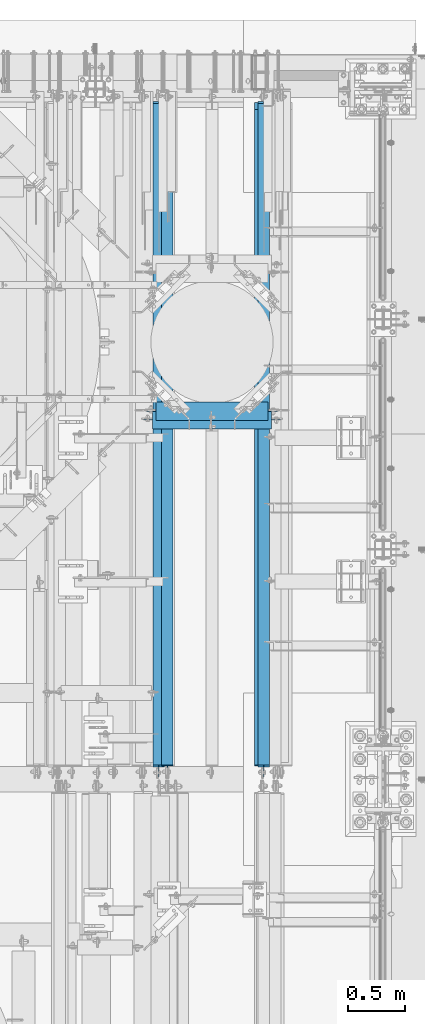
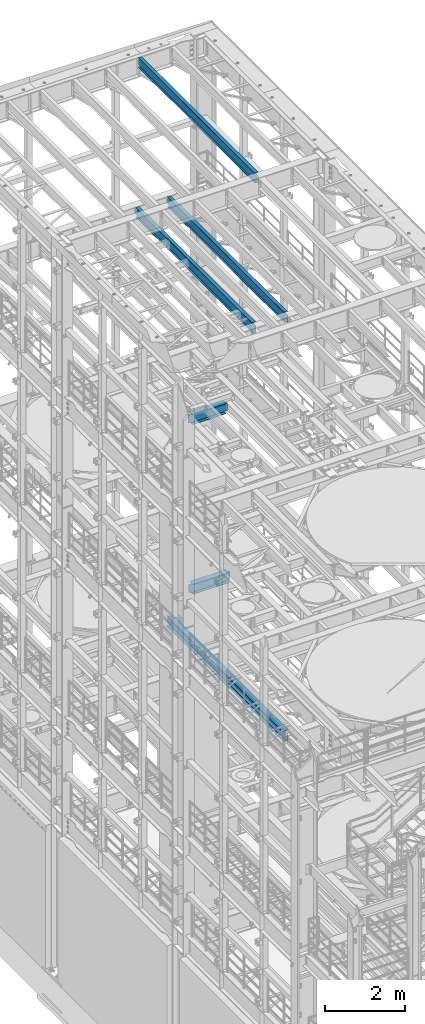
# One storey, part 1062 of 1876: 6 beams, 6 elements without a shape of their own.
"""IFC2X3 building model written with IfcOpenShell, lengths in millimetres."""

from ifc_helpers import new_model, si_unit, frame, origin_with_axes, place, context, subcontext, project, spatial, faceted_brep, material, type_object, element, aggregate, save


model = new_model("IFC2X3")

# Units and contexts
model_context = context("Model", 3, precision=1e-05, world=origin_with_axes())
body_context = subcontext(model_context, "Body", "Model", "MODEL_VIEW")
ifc_project = project(units=[si_unit("LENGTHUNIT", "METRE", prefix="MILLI"), si_unit("AREAUNIT", "SQUARE_METRE"), si_unit("VOLUMEUNIT", "CUBIC_METRE"), si_unit("MASSUNIT", "GRAM", prefix="KILO"), si_unit("TIMEUNIT", "SECOND"), si_unit("PLANEANGLEUNIT", "RADIAN"), si_unit("SOLIDANGLEUNIT", "STERADIAN"), si_unit("THERMODYNAMICTEMPERATUREUNIT", "DEGREE_CELSIUS"), si_unit("LUMINOUSINTENSITYUNIT", "LUMEN")], contexts=[model_context])

# Site, building, storey
site_placement = place(None, origin_with_axes())
site = spatial("IfcSite", under=ifc_project, at=site_placement, CompositionType="ELEMENT")
building_placement = place(site_placement, origin_with_axes())
building = spatial("IfcBuilding", under=site, at=building_placement, Name="Undefined", CompositionType="ELEMENT")
storey_placement = place(building_placement, origin_with_axes())
storey = spatial("IfcBuildingStorey", under=building, at=storey_placement, Name="Undefined", CompositionType="ELEMENT", Elevation=0.0)

# Assembly, beam
assembly_1_placement = place(storey_placement, origin_with_axes())
assembly_1 = element("IfcElementAssembly", 1, at=assembly_1_placement, inside=storey, Name="BEAM", AssemblyPlace="NOTDEFINED", PredefinedType="RIGID_FRAME")
ifc_material_1 = material(Name="STEEL/A992")
beam_type_1 = type_object("IfcBeamType", Name="W12X26", PredefinedType="NOTDEFINED")
beam_1_placement = place(assembly_1_placement, frame((5524.5, 10871.1471065215, 13154.025), z_axis=(0.0, 0.0, 1.0), x_axis=(1.0, 0.0, 0.0)))
beam_1 = element("IfcBeam", 2, at=beam_1_placement, type_object=beam_type_1, material=ifc_material_1, Name="BEAM", ObjectType="W12X26", context=body_context, shape_type="Brep", body=[
    faceted_brep([(6.34999999999945, -3.17499999999927, -130.175000000001), (6.34999999999945, 3.17499999999927, -130.175000000001), (82.550000190734, 3.17499999999927, -130.175000000001), (82.550000190734, -3.17499999999927, -130.175000000001), (87.4100797087794, 3.17499999999927, -131.141729922589), (87.4100797087794, -3.17499999999927, -131.141729922589), (91.5302561769331, 3.17499999999927, -133.894743823066), (91.5302561769331, -3.17499999999927, -133.894743823066), (94.2832700774115, 3.17499999999927, -138.01492029122), (94.2832700774115, -3.17499999999927, -138.01492029122), (95.2499999999991, -3.17499999999927, -142.874999809266), (95.2499999999991, 3.17499999999927, -142.874999809266), (95.2499999999991, 3.17499999999927, -146.049999999999), (95.2499999999991, 82.5499999999993, -146.049999999999), (95.2499999999991, 82.5499999999993, -155.575000000001), (95.2499999999991, -82.5499999999993, -155.575000000001), (95.2499999999991, -82.5499999999993, -146.049999999999), (95.2499999999991, -3.17499999999927, -146.049999999999), (1079.5, 82.5499999999993, 146.049999999999), (1079.5, 3.17499999999927, 146.049999999999), (88.8999999999996, 3.17499999999927, 146.049999999999), (88.8999999999996, 82.5499999999993, 146.049999999999), (76.2000001907345, -3.17499999999927, 130.175000000001), (76.2000001907345, 3.17499999999927, 130.175000000001), (6.34999999999945, 3.17499999999927, 130.175000000001), (6.34999999999945, -3.17499999999927, 130.175000000001), (81.06007970878, -3.17499999999927, 131.141729922589), (81.06007970878, 3.17499999999927, 131.141729922589), (85.1802561769337, -3.17499999999927, 133.894743823066), (85.1802561769337, 3.17499999999927, 133.894743823066), (87.9332700774121, -3.17499999999927, 138.01492029122), (87.9332700774121, 3.17499999999927, 138.01492029122), (88.8999999999996, -3.17499999999927, 142.874999809266), (88.8999999999996, 3.17499999999927, 142.874999809266), (1079.5, -82.5499999999993, 155.575000000001), (1079.5, 82.5499999999993, 155.575000000001), (88.8999999999996, 82.5499999999993, 155.575000000001), (88.8999999999996, -82.5499999999993, 155.575000000001), (1079.5, -82.5499999999993, 146.049999999999), (88.8999999999996, -82.5499999999993, 146.049999999999), (1079.5, -3.17499999999927, 146.049999999999), (88.8999999999996, -3.17499999999927, 146.049999999999), (1079.5, -3.17499999999927, 142.874999809266), (1079.5, 3.17499999999927, 142.874999809266), (1080.46672992259, -3.17499999999927, 138.01492029122), (1080.46672992259, 3.17499999999927, 138.01492029122), (1083.21974382307, -3.17499999999927, 133.894743823066), (1083.21974382307, 3.17499999999927, 133.894743823066), (1087.33992029122, -3.17499999999927, 131.141729922589), (1087.33992029122, 3.17499999999927, 131.141729922589), (1092.19999980927, -3.17499999999927, 130.175000000001), (1092.19999980927, 3.17499999999927, 130.175000000001), (1162.05, -3.17499999999927, 130.175000000001), (1162.05, 3.17499999999927, 130.175000000001), (1162.05, -3.17499999999927, -130.175000000001), (1162.05, 3.17499999999927, -130.175000000001), (1085.84999980927, -3.17499999999927, -130.175000000001), (1085.84999980927, 3.17499999999927, -130.175000000001), (1080.98992029122, -3.17499999999927, -131.141729922589), (1080.98992029122, 3.17499999999927, -131.141729922589), (1076.86974382307, -3.17499999999927, -133.894743823066), (1076.86974382307, 3.17499999999927, -133.894743823066), (1074.11672992259, -3.17499999999927, -138.01492029122), (1074.11672992259, 3.17499999999927, -138.01492029122), (1073.15, -3.17499999999927, -142.874999809266), (1073.15, 3.17499999999927, -142.874999809266), (1073.15, -3.17499999999927, -146.049999999999), (1073.15, -82.5499999999993, -146.049999999999), (1073.15, -82.5499999999993, -155.575000000001), (1073.15, 82.5499999999993, -155.575000000001), (1073.15, 82.5499999999993, -146.049999999999), (1073.15, 3.17499999999927, -146.049999999999)], [[[0, 1, 2, 3]], [[3, 2, 4, 5]], [[5, 4, 6, 7]], [[7, 6, 8, 9]], [[10, 11, 12, 13, 14, 15, 16, 17]], [[9, 8, 11, 10]], [[18, 19, 20, 21]], [[22, 23, 24, 25]], [[26, 27, 23, 22]], [[28, 29, 27, 26]], [[30, 31, 29, 28]], [[32, 33, 31, 30]], [[34, 35, 36, 37]], [[38, 34, 37, 39]], [[40, 38, 39, 41]], [[37, 36, 21, 20, 33, 32, 41, 39]], [[35, 18, 21, 36]], [[34, 38, 40, 42, 43, 19, 18, 35]], [[44, 45, 43, 42]], [[46, 47, 45, 44]], [[48, 49, 47, 46]], [[50, 51, 49, 48]], [[52, 53, 51, 50]], [[53, 52, 54, 55]], [[54, 56, 57, 55]], [[58, 59, 57, 56]], [[60, 61, 59, 58]], [[62, 63, 61, 60]], [[64, 65, 63, 62]], [[66, 67, 68, 69, 70, 71, 65, 64]], [[67, 66, 17, 16]], [[68, 67, 16, 15]], [[69, 68, 15, 14]], [[70, 69, 14, 13]], [[71, 70, 13, 12]], [[6, 4, 2, 1, 24, 23, 27, 29, 31, 33, 20, 19, 43, 45, 47, 49, 51, 53, 55, 57, 59, 61, 63, 65, 71, 12, 11, 8]], [[25, 24, 1, 0]], [[66, 64, 62, 60, 58, 56, 54, 52, 50, 48, 46, 44, 42, 40, 41, 32, 30, 28, 26, 22, 25, 0, 3, 5, 7, 9, 10, 17]]]),
])
aggregate(assembly_1, [beam_1])

assembly_2_placement = place(storey_placement, origin_with_axes())
assembly_2 = element("IfcElementAssembly", 3, at=assembly_2_placement, inside=storey, Name="BEAM", AssemblyPlace="NOTDEFINED", PredefinedType="RIGID_FRAME")
ifc_material_2 = material(Name="STEEL/A36")
beam_2_placement = place(assembly_2_placement, frame((5486.4, 10795.0, 7997.825), z_axis=(0.0, 0.0, -1.0), x_axis=(1.0, 0.0, 0.0)))
beam_2 = element("IfcBeam", 4, at=beam_2_placement, type_object=beam_type_1, material=ifc_material_2, Name="BEAM", ObjectType="W12X26", context=body_context, shape_type="Brep", body=[
    faceted_brep([(1146.175, -3.17499999999927, -146.05), (1146.175, -82.5499999999993, -146.05), (1146.175, -82.5499999999993, -155.575), (1146.175, 82.5499999999993, -155.575), (1146.175, 82.5499999999993, -146.05), (1146.175, 3.17499999999927, -146.05), (1146.175, 3.17499999999927, -142.874999809266), (1146.175, -3.17499999999927, -142.874999809266), (1147.14172992259, 3.17499999999927, -138.014920291221), (1147.14172992259, -3.17499999999927, -138.014920291221), (1149.89474382307, 3.17499999999927, -133.894743823067), (1149.89474382307, -3.17499999999927, -133.894743823067), (1154.01492029122, 3.17499999999927, -131.141729922589), (1154.01492029122, -3.17499999999927, -131.141729922589), (1158.87499980927, 3.17499999999927, -130.175000000001), (1158.87499980927, -3.17499999999927, -130.175000000001), (1228.725, -3.17499999999927, -130.175000000001), (1228.725, 3.17499999999927, -130.175000000001), (1139.825, 82.5499999999993, 146.05), (1139.825, 3.17499999999927, 146.05), (104.774999999999, 3.17499999999927, 146.05), (104.774999999999, 82.5499999999993, 146.05), (98.4250000000002, -3.17500000000018, -142.874999809268), (98.4250000000002, 3.17500000000018, -142.874999809268), (98.4250000000029, 3.17500000000018, -146.049999999999), (98.4250000000002, 82.5500000000002, -146.049999999999), (98.4250000000002, 82.5500000000002, -155.575000000001), (98.4250000000002, -82.5500000000002, -155.575000000001), (98.4250000000002, -82.5500000000002, -146.049999999999), (98.4250000000029, -3.17500000000018, -146.049999999999), (97.4582700774126, -3.17500000000018, -138.014920291222), (97.4582700774126, 3.17500000000018, -138.014920291222), (94.7052561769342, -3.17500000000018, -133.894743823068), (94.7052561769342, 3.17500000000018, -133.894743823068), (90.5850797087805, -3.17500000000018, -131.14172992259), (90.5850797087805, 3.17500000000018, -131.14172992259), (85.725000190735, -3.17500000000018, -130.175000000003), (85.725000190735, 3.17500000000018, -130.175000000003), (15.875, -3.17500000000018, -130.175000000003), (15.875, 3.17500000000018, -130.175000000003), (15.8749999999991, -3.17499999999927, 123.824999999999), (15.8749999999991, 3.17499999999927, 123.824999999999), (92.0750001907336, -3.17499999999927, 123.824999999999), (92.0750001907336, 3.17499999999927, 123.824999999999), (96.9350797087791, -3.17499999999927, 124.791729922586), (96.9350797087791, 3.17499999999927, 124.791729922586), (101.055256176933, -3.17499999999927, 127.544743823065), (101.055256176933, 3.17499999999927, 127.544743823065), (103.808270077411, -3.17499999999927, 131.664920291219), (103.808270077411, 3.17499999999927, 131.664920291219), (104.774999999999, -3.17499999999927, 136.524999809264), (104.774999999999, 3.17499999999927, 136.524999809264), (1139.825, -82.5499999999993, 155.575), (1139.825, 82.5499999999993, 155.575), (104.774999999999, 82.5499999999993, 155.575), (104.774999999999, -82.5499999999993, 155.575), (1139.825, -82.5499999999993, 146.05), (104.774999999999, -82.5499999999993, 146.05), (1139.825, -3.17499999999927, 146.05), (104.774999999999, -3.17499999999927, 146.05), (1139.825, -3.17499999999927, 136.524999809264), (1139.825, 3.17499999999927, 136.524999809264), (1140.79172992259, -3.17499999999927, 131.664920291219), (1140.79172992259, 3.17499999999927, 131.664920291219), (1143.54474382307, -3.17499999999927, 127.544743823065), (1143.54474382307, 3.17499999999927, 127.544743823065), (1147.66492029122, -3.17499999999927, 124.791729922586), (1147.66492029122, 3.17499999999927, 124.791729922586), (1152.52499980927, -3.17499999999927, 123.824999999999), (1152.52499980927, 3.17499999999927, 123.824999999999), (1228.725, -3.17499999999927, 123.824999999999), (1228.725, 3.17499999999927, 123.824999999999)], [[[0, 1, 2, 3, 4, 5, 6, 7]], [[7, 6, 8, 9]], [[9, 8, 10, 11]], [[11, 10, 12, 13]], [[13, 12, 14, 15]], [[16, 15, 14, 17]], [[18, 19, 20, 21]], [[22, 23, 24, 25, 26, 27, 28, 29]], [[30, 31, 23, 22]], [[32, 33, 31, 30]], [[34, 35, 33, 32]], [[36, 37, 35, 34]], [[38, 39, 37, 36]], [[40, 41, 39, 38]], [[42, 43, 41, 40]], [[44, 45, 43, 42]], [[46, 47, 45, 44]], [[48, 49, 47, 46]], [[50, 51, 49, 48]], [[52, 53, 54, 55]], [[56, 52, 55, 57]], [[58, 56, 57, 59]], [[55, 54, 21, 20, 51, 50, 59, 57]], [[53, 18, 21, 54]], [[52, 56, 58, 60, 61, 19, 18, 53]], [[62, 63, 61, 60]], [[64, 65, 63, 62]], [[66, 67, 65, 64]], [[68, 69, 67, 66]], [[70, 71, 69, 68]], [[71, 70, 16, 17]], [[12, 10, 8, 6, 5, 24, 23, 31, 33, 35, 37, 39, 41, 43, 45, 47, 49, 51, 20, 19, 61, 63, 65, 67, 69, 71, 17, 14]], [[25, 24, 5, 4]], [[26, 25, 4, 3]], [[27, 26, 3, 2]], [[28, 27, 2, 1]], [[29, 28, 1, 0]], [[70, 68, 66, 64, 62, 60, 58, 59, 50, 48, 46, 44, 42, 40, 38, 36, 34, 32, 30, 22, 29, 0, 7, 9, 11, 13, 15, 16]]]),
])
aggregate(assembly_2, [beam_2])

assembly_3_placement = place(storey_placement, origin_with_axes())
assembly_3 = element("IfcElementAssembly", 5, at=assembly_3_placement, inside=storey, Name="BEAM", AssemblyPlace="NOTDEFINED", PredefinedType="RIGID_FRAME")
beam_type_2 = type_object("IfcBeamType", Name="W12X16", PredefinedType="NOTDEFINED")
beam_3_placement = place(assembly_3_placement, frame((6565.9, 7620.0, 17830.8), z_axis=(0.0, 0.0, 1.0), x_axis=(0.0, 1.0, 0.0)))
beam_3 = element("IfcBeam", 6, at=beam_3_placement, type_object=beam_type_2, material=ifc_material_1, Name="BEAM", ObjectType="W12X16", context=body_context, shape_type="Brep", body=[
    faceted_brep([(19.84375, -3.17499999999995, -126.999999999996), (19.84375, 3.17499999999995, -126.999999999996), (96.0437501907345, 3.17500002364682, -126.999999999996), (96.0437501907345, -3.17499999999995, -126.999999999996), (100.90382970878, 3.17500002380461, -127.966729922584), (100.90382970878, -3.17499999999995, -127.966729922584), (105.024006176934, 3.17500002425209, -130.719743823061), (105.024006176934, -3.17499999999995, -130.719743823061), (107.777020077412, 3.17500002492102, -134.839920291215), (107.777020077412, -3.17499999999995, -134.839920291215), (108.74375, -3.17499999999995, -139.699999809261), (108.74375, 3.17500002570978, -139.699999809261), (108.74375, 3.17500009516311, -146.049999999999), (108.74375, 50.8, -146.049999999999), (108.74375, 50.8, -152.400000000001), (108.74375, -50.8, -152.400000000001), (108.74375, -50.8, -146.049999999999), (108.74375, -3.17499999999995, -146.049999999999), (5969.79375, 50.8, 146.049999999999), (5969.79375, 3.17499999999995, 146.049999999999), (127.79375, 3.17500000000018, 146.05), (127.79375, 50.8000000000002, 146.05), (115.093750190735, -3.17500000000018, 107.950000000004), (115.093750190735, 3.17499998606036, 107.950000000004), (19.84375, 3.17499999999995, 107.950000000004), (19.84375, -3.17499999999995, 107.950000000004), (119.95382970878, -3.17500000000018, 108.916729922592), (119.95382970878, 3.17499998590392, 108.916729922592), (124.074006176934, -3.17500000000018, 111.669743823069), (124.074006176934, 3.17499998545827, 111.669743823069), (126.827020077412, -3.17500000000018, 115.789920291223), (126.827020077412, 3.17499998479161, 115.789920291223), (127.79375, -3.17500000000018, 120.64999980927), (127.79375, 3.17499998400399, 120.64999980927), (5969.79375, -50.8, 152.400000000001), (5969.79375, 50.8, 152.400000000001), (127.79375, 50.8000000000002, 152.4), (127.79375, -50.8000000000002, 152.4), (5969.79375, -50.8, 146.049999999999), (127.79375, -50.8000000000002, 146.05), (5969.79375, -3.17499999999995, 146.049999999999), (127.79375, -3.17500000000018, 146.05), (5969.79375, -3.17499999999995, 120.64999980927), (5969.79375, 3.17499999999995, 120.64999980927), (5970.76047992259, -3.17499999999995, 115.789920291223), (5970.76047992259, 3.17499999999995, 115.789920291223), (5973.51349382307, -3.17499999999995, 111.669743823069), (5973.51349382307, 3.17499999999995, 111.669743823069), (5977.63367029122, -3.17499999999995, 108.916729922592), (5977.63367029122, 3.17499999999995, 108.916729922592), (5982.49374980927, -3.17499999999995, 107.950000000004), (5982.49374980927, 3.17499999999995, 107.950000000004), (6076.15625, -3.17499999999995, 107.950000000004), (6076.15625, 3.17499999999995, 107.950000000004), (6076.15625, -3.17499999999995, -126.999999999996), (6076.15625, 3.17499999999995, -126.999999999996), (5999.95624980926, -3.17499999999995, -126.999999999996), (5999.95624980926, 3.17499999999995, -126.999999999996), (5995.09617029122, -3.17499999999995, -127.966729922584), (5995.09617029122, 3.17499999999995, -127.966729922584), (5990.97599382306, -3.17499999999995, -130.719743823061), (5990.97599382306, 3.17499999999995, -130.719743823061), (5988.22297992259, -3.17499999999995, -134.839920291215), (5988.22297992259, 3.17499999999995, -134.839920291215), (5987.25625, -3.17499999999995, -139.699999809261), (5987.25625, 3.17499999999995, -139.699999809261), (5987.25625, -3.17499999999995, -146.049999999999), (5987.25625, -50.8, -146.049999999999), (5987.25625, -50.8, -152.400000000001), (5987.25625, 50.8, -152.400000000001), (5987.25625, 50.8, -146.049999999999), (5987.25625, 3.17499999999995, -146.049999999999)], [[[0, 1, 2, 3]], [[3, 2, 4, 5]], [[5, 4, 6, 7]], [[7, 6, 8, 9]], [[10, 11, 12, 13, 14, 15, 16, 17]], [[9, 8, 11, 10]], [[18, 19, 20, 21]], [[22, 23, 24, 25]], [[26, 27, 23, 22]], [[28, 29, 27, 26]], [[30, 31, 29, 28]], [[32, 33, 31, 30]], [[34, 35, 36, 37]], [[38, 34, 37, 39]], [[40, 38, 39, 41]], [[37, 36, 21, 20, 33, 32, 41, 39]], [[35, 18, 21, 36]], [[34, 38, 40, 42, 43, 19, 18, 35]], [[44, 45, 43, 42]], [[46, 47, 45, 44]], [[48, 49, 47, 46]], [[50, 51, 49, 48]], [[52, 53, 51, 50]], [[53, 52, 54, 55]], [[54, 56, 57, 55]], [[58, 59, 57, 56]], [[60, 61, 59, 58]], [[62, 63, 61, 60]], [[64, 65, 63, 62]], [[66, 67, 68, 69, 70, 71, 65, 64]], [[67, 66, 17, 16]], [[68, 67, 16, 15]], [[69, 68, 15, 14]], [[70, 69, 14, 13]], [[71, 70, 13, 12]], [[6, 4, 2, 1, 24, 23, 27, 29, 31, 33, 20, 19, 43, 45, 47, 49, 51, 53, 55, 57, 59, 61, 63, 65, 71, 12, 11, 8]], [[25, 24, 1, 0]], [[66, 64, 62, 60, 58, 56, 54, 52, 50, 48, 46, 44, 42, 40, 41, 32, 30, 28, 26, 22, 25, 0, 3, 5, 7, 9, 10, 17]]]),
])
aggregate(assembly_3, [beam_3])

assembly_4_placement = place(storey_placement, origin_with_axes())
assembly_4 = element("IfcElementAssembly", 7, at=assembly_4_placement, inside=storey, Name="BEAM", AssemblyPlace="NOTDEFINED", PredefinedType="RIGID_FRAME")
beam_4_placement = place(assembly_4_placement, frame((5638.8, 7620.0, 17830.8), z_axis=(0.0, 0.0, 1.0), x_axis=(0.0, 1.0, 0.0)))
beam_4 = element("IfcBeam", 8, at=beam_4_placement, type_object=beam_type_2, material=ifc_material_1, Name="BEAM", ObjectType="W12X16", context=body_context, shape_type="Brep", body=[
    faceted_brep([(19.84375, -3.17499999999995, -126.999999999996), (19.84375, 3.17499999999995, -126.999999999996), (96.0437501907345, 3.17500002364682, -126.999999999996), (96.0437501907345, -3.17499999999995, -126.999999999996), (100.90382970878, 3.17500002380461, -127.966729922584), (100.90382970878, -3.17499999999995, -127.966729922584), (105.024006176934, 3.17500002425209, -130.719743823061), (105.024006176934, -3.17499999999995, -130.719743823061), (107.777020077412, 3.17500002492102, -134.839920291215), (107.777020077412, -3.17499999999995, -134.839920291215), (108.74375, -3.17499999999995, -139.699999809261), (108.74375, 3.17500002570978, -139.699999809261), (108.74375, 3.17500009516311, -146.049999999999), (108.74375, 50.8, -146.049999999999), (108.74375, 50.8, -152.400000000001), (108.74375, -50.8, -152.400000000001), (108.74375, -50.8, -146.049999999999), (108.74375, -3.17499999999995, -146.049999999999), (5969.79375, 50.8, 146.049999999999), (5969.79375, 3.17499999999995, 146.049999999999), (126.20625, 3.17499999999995, 146.049999999999), (126.20625, 50.8, 146.049999999999), (113.506250190735, -3.17499999999995, 107.950000000004), (113.506250190735, 3.17499998606149, 107.950000000004), (19.84375, 3.17499999999995, 107.950000000004), (19.84375, -3.17499999999995, 107.950000000004), (118.366329708781, -3.17499999999995, 108.916729922592), (118.366329708781, 3.17499998590552, 108.916729922592), (122.486506176934, -3.17499999999995, 111.669743823069), (122.486506176934, 3.17499998546009, 111.669743823069), (125.239520077413, -3.17499999999995, 115.789920291223), (125.239520077413, 3.17499998479298, 115.789920291223), (126.20625, -3.17499999999995, 120.64999980927), (126.20625, 3.17499998400558, 120.64999980927), (5969.79375, -50.8, 152.400000000001), (5969.79375, 50.8, 152.400000000001), (126.20625, 50.8, 152.400000000001), (126.20625, -50.8, 152.400000000001), (5969.79375, -50.8, 146.049999999999), (126.20625, -50.8, 146.049999999999), (5969.79375, -3.17499999999995, 146.049999999999), (126.20625, -3.17499999999995, 146.049999999999), (5969.79375, -3.17499999999995, 120.64999980927), (5969.79375, 3.17499999999995, 120.64999980927), (5970.76047992259, -3.17499999999995, 115.789920291223), (5970.76047992259, 3.17499999999995, 115.789920291223), (5973.51349382307, -3.17499999999995, 111.669743823069), (5973.51349382307, 3.17499999999995, 111.669743823069), (5977.63367029122, -3.17499999999995, 108.916729922592), (5977.63367029122, 3.17499999999995, 108.916729922592), (5982.49374980927, -3.17499999999995, 107.950000000004), (5982.49374980927, 3.17499999999995, 107.950000000004), (6076.15625, -3.17499999999995, 107.950000000004), (6076.15625, 3.17499999999995, 107.950000000004), (6076.15625, -3.17499999999995, -126.999999999996), (6076.15625, 3.17499999999995, -126.999999999996), (5999.95624980926, -3.17499999999995, -126.999999999996), (5999.95624980926, 3.17499999999995, -126.999999999996), (5995.09617029122, -3.17499999999995, -127.966729922584), (5995.09617029122, 3.17499999999995, -127.966729922584), (5990.97599382306, -3.17499999999995, -130.719743823061), (5990.97599382306, 3.17499999999995, -130.719743823061), (5988.22297992259, -3.17499999999995, -134.839920291215), (5988.22297992259, 3.17499999999995, -134.839920291215), (5987.25625, -3.17499999999995, -139.699999809261), (5987.25625, 3.17499999999995, -139.699999809261), (5987.25625, -3.17499999999995, -146.049999999999), (5987.25625, -50.8, -146.049999999999), (5987.25625, -50.8, -152.400000000001), (5987.25625, 50.8, -152.400000000001), (5987.25625, 50.8, -146.049999999999), (5987.25625, 3.17499999999995, -146.049999999999)], [[[0, 1, 2, 3]], [[3, 2, 4, 5]], [[5, 4, 6, 7]], [[7, 6, 8, 9]], [[10, 11, 12, 13, 14, 15, 16, 17]], [[9, 8, 11, 10]], [[18, 19, 20, 21]], [[22, 23, 24, 25]], [[26, 27, 23, 22]], [[28, 29, 27, 26]], [[30, 31, 29, 28]], [[32, 33, 31, 30]], [[34, 35, 36, 37]], [[38, 34, 37, 39]], [[40, 38, 39, 41]], [[37, 36, 21, 20, 33, 32, 41, 39]], [[35, 18, 21, 36]], [[34, 38, 40, 42, 43, 19, 18, 35]], [[44, 45, 43, 42]], [[46, 47, 45, 44]], [[48, 49, 47, 46]], [[50, 51, 49, 48]], [[52, 53, 51, 50]], [[53, 52, 54, 55]], [[54, 56, 57, 55]], [[58, 59, 57, 56]], [[60, 61, 59, 58]], [[62, 63, 61, 60]], [[64, 65, 63, 62]], [[66, 67, 68, 69, 70, 71, 65, 64]], [[67, 66, 17, 16]], [[68, 67, 16, 15]], [[69, 68, 15, 14]], [[70, 69, 14, 13]], [[71, 70, 13, 12]], [[6, 4, 2, 1, 24, 23, 27, 29, 31, 33, 20, 19, 43, 45, 47, 49, 51, 53, 55, 57, 59, 61, 63, 65, 71, 12, 11, 8]], [[25, 24, 1, 0]], [[66, 64, 62, 60, 58, 56, 54, 52, 50, 48, 46, 44, 42, 40, 41, 32, 30, 28, 26, 22, 25, 0, 3, 5, 7, 9, 10, 17]]]),
])
aggregate(assembly_4, [beam_4])

assembly_5_placement = place(storey_placement, origin_with_axes())
assembly_5 = element("IfcElementAssembly", 9, at=assembly_5_placement, inside=storey, Name="BEAM", AssemblyPlace="NOTDEFINED", PredefinedType="RIGID_FRAME")
beam_5_placement = place(assembly_5_placement, frame((5715.0, 7620.0, 22402.8), z_axis=(0.0, 0.0, 1.0), x_axis=(0.0, 1.0, 0.0)))
beam_5 = element("IfcBeam", 10, at=beam_5_placement, type_object=beam_type_2, material=ifc_material_1, Name="BEAM", ObjectType="W12X16", context=body_context, shape_type="Brep", body=[
    faceted_brep([(19.84375, -3.17499999999995, -126.999999999996), (19.84375, 3.17499999999995, -126.999999999996), (102.393750190735, 3.17500000000018, -127.000000000001), (102.393750190735, -3.17500000000018, -127.000000000001), (107.25382970878, 3.17500000000018, -127.966729922588), (107.25382970878, -3.17500000000018, -127.966729922588), (111.374006176934, 3.17500000000018, -130.719743823067), (111.374006176934, -3.17500000000018, -130.719743823067), (114.127020077412, 3.17500000000018, -134.839920291221), (114.127020077412, -3.17500000000018, -134.839920291221), (115.09375, -3.17500000000018, -139.699999809266), (115.09375, 3.17500000000018, -139.699999809266), (115.09375, 3.17500000000018, -146.05), (115.09375, 50.8000000000002, -146.05), (115.09375, 50.8000000000002, -152.4), (115.09375, -50.8000000000002, -152.4), (115.09375, -50.8000000000002, -146.05), (115.09375, -3.17500000000018, -146.05), (127.79375, 3.17500000000018, 146.05), (127.79375, 50.8000000000002, 146.05), (5968.20625, 50.8, 146.05), (5968.20625, 3.17499999999995, 146.05), (115.093750190735, -3.17500000000018, 114.299999999999), (115.093750190735, 3.17500000000018, 114.299999999999), (19.84375, 3.17500000000018, 114.299999999999), (19.84375, -3.17500000000018, 114.299999999999), (119.95382970878, -3.17500000000018, 115.266729922587), (119.95382970878, 3.17500000000018, 115.266729922587), (124.074006176934, -3.17500000000018, 118.019743823065), (124.074006176934, 3.17500000000018, 118.019743823065), (126.827020077412, -3.17500000000018, 122.139920291219), (126.827020077412, 3.17500000000018, 122.139920291219), (127.79375, -3.17500000000018, 126.999999809264), (127.79375, 3.17500000000018, 126.999999809264), (127.79375, 50.8000000000002, 152.4), (127.79375, -50.8000000000002, 152.4), (5968.20625, -50.8, 152.4), (5968.20625, 50.8, 152.4), (127.79375, -50.8000000000002, 146.05), (5968.20625, -50.8, 146.05), (127.79375, -3.17500000000018, 146.05), (5968.20625, -3.17499999999995, 146.05), (5968.20625, -3.17499999999995, 126.999999809264), (5968.20625, 3.17499999999995, 126.999999809264), (5969.17297992259, -3.17499999999995, 122.139920291219), (5969.17297992259, 3.17499999999995, 122.139920291219), (5971.92599382307, -3.17499999999995, 118.019743823065), (5971.92599382307, 3.17499999999995, 118.019743823065), (5976.04617029122, -3.17499999999995, 115.266729922587), (5976.04617029122, 3.17499999999995, 115.266729922587), (5980.90624980927, -3.17499999999995, 114.299999999999), (5980.90624980927, 3.17499999999995, 114.299999999999), (6076.15625, -3.17499999999995, 114.299999999999), (6076.15625, 3.17499999999995, 114.299999999999), (6076.15625, -3.17499999999995, -126.999999999996), (6076.15625, 3.17499999999995, -126.999999999996), (5993.60624980927, -3.17499999999995, -127.000000000001), (5993.60624980927, 3.17499999999995, -127.000000000001), (5988.74617029122, -3.17499999999995, -127.966729922588), (5988.74617029122, 3.17499999999995, -127.966729922588), (5984.62599382307, -3.17499999999995, -130.719743823067), (5984.62599382307, 3.17499999999995, -130.719743823067), (5981.87297992259, -3.17499999999995, -134.839920291221), (5981.87297992259, 3.17499999999995, -134.839920291221), (5980.90625, -3.17499999999995, -139.699999809266), (5980.90625, 3.17499999999995, -139.699999809266), (5980.90625, -3.17499999999995, -146.05), (5980.90625, -50.8, -146.05), (5980.90625, -50.8, -152.4), (5980.90625, 50.8, -152.4), (5980.90625, 50.8, -146.05), (5980.90625, 3.17499999999995, -146.05)], [[[0, 1, 2, 3]], [[3, 2, 4, 5]], [[5, 4, 6, 7]], [[7, 6, 8, 9]], [[10, 11, 12, 13, 14, 15, 16, 17]], [[9, 8, 11, 10]], [[18, 19, 20, 21]], [[22, 23, 24, 25]], [[26, 27, 23, 22]], [[28, 29, 27, 26]], [[30, 31, 29, 28]], [[32, 33, 31, 30]], [[34, 35, 36, 37]], [[35, 38, 39, 36]], [[38, 40, 41, 39]], [[35, 34, 19, 18, 33, 32, 40, 38]], [[19, 34, 37, 20]], [[36, 39, 41, 42, 43, 21, 20, 37]], [[44, 45, 43, 42]], [[46, 47, 45, 44]], [[48, 49, 47, 46]], [[50, 51, 49, 48]], [[52, 53, 51, 50]], [[53, 52, 54, 55]], [[54, 56, 57, 55]], [[58, 59, 57, 56]], [[60, 61, 59, 58]], [[62, 63, 61, 60]], [[64, 65, 63, 62]], [[66, 67, 68, 69, 70, 71, 65, 64]], [[17, 16, 67, 66]], [[16, 15, 68, 67]], [[15, 14, 69, 68]], [[14, 13, 70, 69]], [[13, 12, 71, 70]], [[59, 61, 63, 65, 71, 12, 11, 8, 6, 4, 2, 1, 24, 23, 27, 29, 31, 33, 18, 21, 43, 45, 47, 49, 51, 53, 55, 57]], [[25, 24, 1, 0]], [[52, 50, 48, 46, 44, 42, 41, 40, 32, 30, 28, 26, 22, 25, 0, 3, 5, 7, 9, 10, 17, 66, 64, 62, 60, 58, 56, 54]]]),
])
aggregate(assembly_5, [beam_5])

assembly_6_placement = place(storey_placement, origin_with_axes())
assembly_6 = element("IfcElementAssembly", 11, at=assembly_6_placement, inside=storey, Name="BEAM", AssemblyPlace="NOTDEFINED", PredefinedType="RIGID_FRAME")
beam_type_3 = type_object("IfcBeamType", Name="W12X30", PredefinedType="NOTDEFINED")
beam_6_placement = place(assembly_6_placement, frame((6565.9, 7620.0, 4973.6375), z_axis=(0.0, 0.0, 1.0), x_axis=(0.0, 1.0, 0.0)))
beam_6 = element("IfcBeam", 12, at=beam_6_placement, type_object=beam_type_3, material=ifc_material_1, Name="BEAM", ObjectType="W12X30", context=body_context, shape_type="Brep", body=[
    faceted_brep([(19.8437500000002, -3.17500000000018, -131.762499999993), (19.8437500000002, 3.17500000000018, -131.762499999993), (102.393750190735, 3.17500000000018, -131.762500000001), (102.393750190735, -3.17500000000018, -131.762500000001), (107.25382970878, 3.17500000000018, -132.729229922588), (107.25382970878, -3.17500000000018, -132.729229922588), (111.374006176934, 3.17500000000018, -135.482243823067), (111.374006176934, -3.17500000000018, -135.482243823067), (114.127020077412, 3.17500000000018, -139.60242029122), (114.127020077412, -3.17500000000018, -139.60242029122), (115.09375, -3.17500000000018, -144.462499809266), (115.09375, 3.17500000000018, -144.462499809266), (115.09375, 3.17500000000018, -146.05), (115.09375, 82.5500000000002, -146.05), (115.09375, 82.5500000000002, -157.1625), (115.09375, -82.5500000000002, -157.1625), (115.09375, -82.5500000000002, -146.05), (115.09375, -3.17500000000018, -146.05), (5914.23125, 82.5500000000002, 146.05), (5914.23125, 3.17500000000018, 146.05), (127.79375, 3.17500000000018, 146.05), (127.793782276814, 82.5500000000102, 146.05), (115.09374930124, -3.17499999999995, 119.062500000004), (115.09374930124, 3.17499999999995, 119.062500000004), (19.8437491105051, 3.17499999999995, 119.062500000004), (19.8437491105051, -3.17499999999995, 119.062500000004), (119.953828819285, -3.17499999999995, 120.029229922591), (119.953828819285, 3.17499999999995, 120.029229922591), (124.074005287439, -3.17499999999995, 122.782243823069), (124.074005287439, 3.17499999999995, 122.782243823069), (126.827019187917, -3.17499999999995, 126.902420291222), (126.827019187917, 3.17499999999995, 126.902420291222), (127.793749110505, -3.17499999999995, 131.762499809269), (127.793749110505, 3.17499999999995, 131.762499809269), (5914.23125, -82.5500000000002, 157.1625), (5914.23125, 82.5500000000002, 157.1625), (127.793749110505, 82.55, 157.162499999999), (127.793749110505, -82.55, 157.162499999999), (5914.23125, -82.5500000000002, 146.05), (127.793782276821, -82.5500000000029, 146.05), (5914.23125, -3.17500000000018, 146.05), (127.79375, -3.17500000000018, 146.05), (5914.23125, -3.17500000000018, 119.062499809265), (5914.23125, 3.17500000000018, 119.062499809265), (5915.19797992259, -3.17500000000018, 114.20242029122), (5915.19797992259, 3.17500000000018, 114.20242029122), (5917.95099382307, -3.17500000000018, 110.082243823066), (5917.95099382307, 3.17500000000018, 110.082243823066), (5922.07117029122, -3.17500000000018, 107.329229922588), (5922.07117029122, 3.17500000000018, 107.329229922588), (5926.93124980926, -3.17500000000018, 106.3625), (5926.93124980926, 3.17500000000018, 106.3625), (6072.98125, -3.17500000000018, 106.3625), (6072.98125, 3.17500000000018, 106.3625), (6072.98125, -3.17500000000018, -131.7625), (6072.98125, 3.17500000000018, -131.7625), (5990.43124980926, -3.17500000000018, -131.7625), (5990.43124980926, 3.17500000000018, -131.7625), (5985.57117029122, -3.17500000000018, -132.729229922587), (5985.57117029122, 3.17500000000018, -132.729229922587), (5981.45099382307, -3.17500000000018, -135.482243823066), (5981.45099382307, 3.17500000000018, -135.482243823066), (5978.69797992259, -3.17500000000018, -139.602420291219), (5978.69797992259, 3.17500000000018, -139.602420291219), (5977.73125, -3.17500000000018, -144.462499809265), (5977.73125, 3.17500000000018, -144.462499809265), (5977.73125, -3.17500000000018, -146.05), (5977.73125, -82.5500000000002, -146.05), (5977.73125, -82.5500000000002, -157.1625), (5977.73125, 82.5500000000002, -157.1625), (5977.73125, 82.5500000000002, -146.05), (5977.73125, 3.17500000000018, -146.05)], [[[0, 1, 2, 3]], [[3, 2, 4, 5]], [[5, 4, 6, 7]], [[7, 6, 8, 9]], [[10, 11, 12, 13, 14, 15, 16, 17]], [[9, 8, 11, 10]], [[18, 19, 20, 21]], [[22, 23, 24, 25]], [[26, 27, 23, 22]], [[28, 29, 27, 26]], [[30, 31, 29, 28]], [[32, 33, 31, 30]], [[34, 35, 36, 37]], [[38, 34, 37, 39]], [[40, 38, 39, 41]], [[37, 36, 21, 20, 33, 32, 41, 39]], [[35, 18, 21, 36]], [[34, 38, 40, 42, 43, 19, 18, 35]], [[44, 45, 43, 42]], [[46, 47, 45, 44]], [[48, 49, 47, 46]], [[50, 51, 49, 48]], [[52, 53, 51, 50]], [[53, 52, 54, 55]], [[54, 56, 57, 55]], [[58, 59, 57, 56]], [[60, 61, 59, 58]], [[62, 63, 61, 60]], [[64, 65, 63, 62]], [[66, 67, 68, 69, 70, 71, 65, 64]], [[67, 66, 17, 16]], [[68, 67, 16, 15]], [[69, 68, 15, 14]], [[70, 69, 14, 13]], [[71, 70, 13, 12]], [[6, 4, 2, 1, 24, 23, 27, 29, 31, 33, 20, 19, 43, 45, 47, 49, 51, 53, 55, 57, 59, 61, 63, 65, 71, 12, 11, 8]], [[25, 24, 1, 0]], [[66, 64, 62, 60, 58, 56, 54, 52, 50, 48, 46, 44, 42, 40, 41, 32, 30, 28, 26, 22, 25, 0, 3, 5, 7, 9, 10, 17]]]),
])
aggregate(assembly_6, [beam_6])

save(model, "model.ifc")
